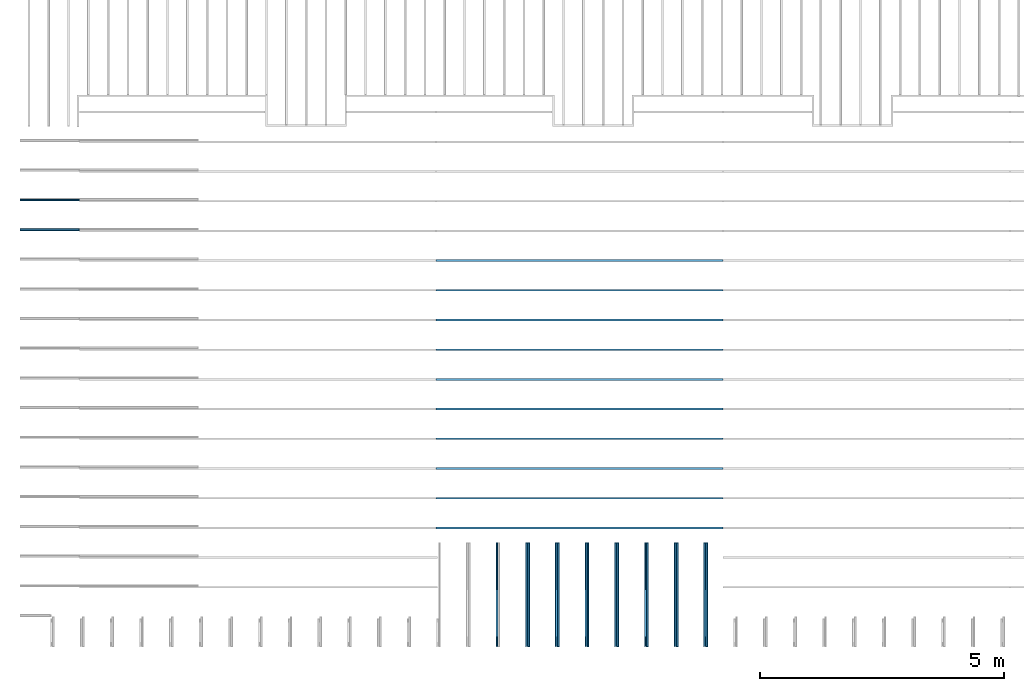
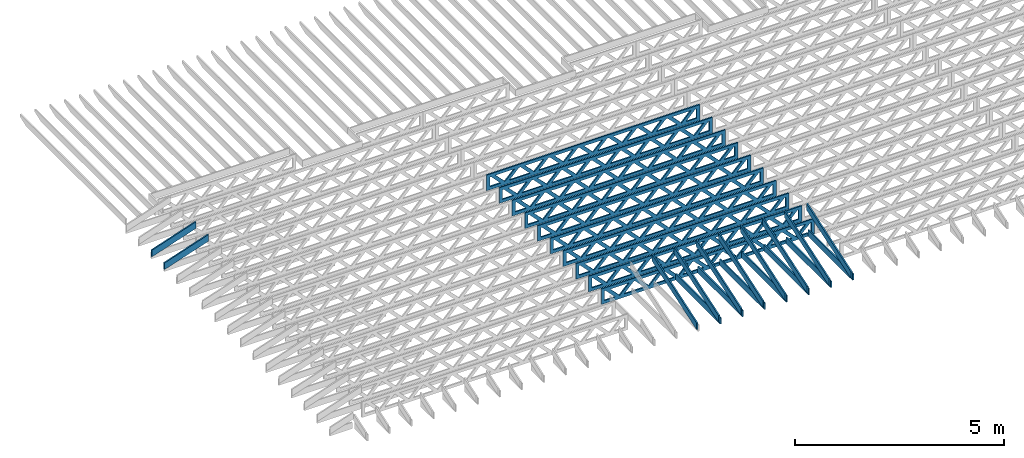
# One storey, part 3 of 18: 27 beams, 4 elements without a shape of their own.
"""IFC4 building model written with IfcOpenShell, lengths in feet."""

from ifc_helpers import new_model, entity, si_unit, converted_unit, derived_unit, direction, frame, frame_2d, origin, origin_2d_with_axis, place, context, subcontext, project, spatial, rectangle, extrude, clip, halfspace, source, transform, mapped, material, material_profile, profile_set, profile_usage, type_object, type_shapes, element, aggregate, save


model = new_model("IFC4")

# Units and contexts
model_context_1 = context("Model", 3, precision=0.0001, world=origin(), true_north=direction((6.12303176911189e-17, 1.0)))
model_context_2 = context("Model", 3, precision=0.0001, world=origin(), true_north=direction((6.12303176911189e-17, 1.0)))
body_context = subcontext(model_context_2, "Body", "Model", "MODEL_VIEW")
ifc_project = project(units=[converted_unit("LENGTHUNIT", "FOOT", entity("IfcRatioMeasure", 0.3048), si_unit("LENGTHUNIT", "METRE"), dimensions=[1, 0, 0, 0, 0, 0, 0]), converted_unit("AREAUNIT", "SQUARE FOOT", entity("IfcRatioMeasure", 0.09290304), si_unit("AREAUNIT", "SQUARE_METRE"), dimensions=[2, 0, 0, 0, 0, 0, 0]), converted_unit("VOLUMEUNIT", "CUBIC FOOT", entity("IfcRatioMeasure", 0.028316846592), si_unit("VOLUMEUNIT", "CUBIC_METRE"), dimensions=[3, 0, 0, 0, 0, 0, 0]), converted_unit("PLANEANGLEUNIT", "DEGREE", entity("IfcRatioMeasure", 0.0174532925199433), si_unit("PLANEANGLEUNIT", "RADIAN"), dimensions=[0, 0, 0, 0, 0, 0, 0]), si_unit("MASSUNIT", "GRAM", prefix="KILO"), derived_unit("MASSDENSITYUNIT", [(si_unit("MASSUNIT", "GRAM", prefix="KILO"), 1), (si_unit("LENGTHUNIT", "METRE"), -3)]), derived_unit("MOMENTOFINERTIAUNIT", [(si_unit("LENGTHUNIT", "METRE"), 4)]), si_unit("TIMEUNIT", "SECOND"), si_unit("FREQUENCYUNIT", "HERTZ"), si_unit("THERMODYNAMICTEMPERATUREUNIT", "DEGREE_CELSIUS"), derived_unit("THERMALTRANSMITTANCEUNIT", [(si_unit("MASSUNIT", "GRAM", prefix="KILO"), 1), (si_unit("THERMODYNAMICTEMPERATUREUNIT", "KELVIN"), -1), (si_unit("TIMEUNIT", "SECOND"), -3)]), derived_unit("VOLUMETRICFLOWRATEUNIT", [(si_unit("LENGTHUNIT", "METRE"), 3), (si_unit("TIMEUNIT", "SECOND"), -1)]), si_unit("ELECTRICCURRENTUNIT", "AMPERE"), si_unit("ELECTRICVOLTAGEUNIT", "VOLT"), si_unit("POWERUNIT", "WATT"), si_unit("FORCEUNIT", "NEWTON"), si_unit("ILLUMINANCEUNIT", "LUX"), si_unit("LUMINOUSFLUXUNIT", "LUMEN"), si_unit("LUMINOUSINTENSITYUNIT", "CANDELA"), derived_unit("USERDEFINED", [(si_unit("MASSUNIT", "GRAM", prefix="KILO"), -1), (si_unit("LENGTHUNIT", "METRE"), -2), (si_unit("TIMEUNIT", "SECOND"), 3), (si_unit("LUMINOUSFLUXUNIT", "LUMEN"), 1)]), derived_unit("LINEARVELOCITYUNIT", [(si_unit("LENGTHUNIT", "METRE"), 1), (si_unit("TIMEUNIT", "SECOND"), -1)]), si_unit("PRESSUREUNIT", "PASCAL"), derived_unit("USERDEFINED", [(si_unit("LENGTHUNIT", "METRE"), -2), (si_unit("MASSUNIT", "GRAM", prefix="KILO"), 1), (si_unit("TIMEUNIT", "SECOND"), -2)]), derived_unit("LINEARFORCEUNIT", [(si_unit("MASSUNIT", "GRAM", prefix="KILO"), 1), (si_unit("LENGTHUNIT", "METRE"), 1), (si_unit("TIMEUNIT", "SECOND"), -2), (si_unit("LENGTHUNIT", "METRE"), -1)]), derived_unit("PLANARFORCEUNIT", [(si_unit("MASSUNIT", "GRAM", prefix="KILO"), 1), (si_unit("LENGTHUNIT", "METRE"), 1), (si_unit("TIMEUNIT", "SECOND"), -2), (si_unit("LENGTHUNIT", "METRE"), -2)])], contexts=[model_context_1])

# Site, building, storey
site_placement = place(None, origin())
site = spatial("IfcSite", under=ifc_project, at=site_placement, CompositionType="ELEMENT")
building_placement = place(site_placement, origin())
building = spatial("IfcBuilding", under=site, at=building_placement, CompositionType="ELEMENT")
storey_placement = place(building_placement, frame((0.0, 0.0, 30.4375000000082)))
storey = spatial("IfcBuildingStorey", under=building, at=storey_placement, Name="ROOF", CompositionType="ELEMENT", Elevation=30.4375000000082)

# Assembly, beams
assembly_1_placement = place(storey_placement, origin())
assembly_1 = element("IfcElementAssembly", 1, at=assembly_1_placement, inside=storey, Name="Structural Beam System:Structural Framing System", ObjectType="Structural Beam System:Structural Framing System", AssemblyPlace="NOTDEFINED", PredefinedType="BEAM_GRID")
ifc_material_1 = material(Name="TOP CHORD OF FIELD FRAMED OVERHANG", Category="Materials")
ifc_material_profile_1 = material_profile(ifc_material_1, rectangle(XDim=0.604166666666667, YDim=0.125, at=origin_2d_with_axis()), Name="2X8 TOP CHORD")
ifc_profile_set_1 = profile_set([ifc_material_profile_1], Name="2X8 TOP CHORD")
ifc_profile_usage_1 = profile_usage(ifc_profile_set_1, cardinal=8)
beam_type_1 = type_object("IfcBeamType", Name="Dimension Lumber - Ends:2X8 TOP CHORD", PredefinedType="BEAM", material=ifc_profile_set_1)
shared_shape_1 = source(origin(), body_context, "Body", "Clipping", [
    clip(clip(extrude(rectangle(XDim=0.604166666666671, YDim=0.125, at=frame_2d((-1.83186799063151e-15, 0.0), x_axis=(1.0, 0.0))), frame((-2.10819527564865, 0.0, 0.0), z_axis=(1.0, 0.0, 0.0), x_axis=(0.0, 0.0, -1.0)), (0.0, 0.0, 1.0), 4.41772145980974), halfspace(frame((2.10819527564862, -0.0625000000000025, -0.302083333333339), z_axis=(0.948710608132914, 0.0, -0.316145823973807), x_axis=(0.0, 1.0, 0.0)), False)), halfspace(frame((-1.90686436713617, -0.0625000000000025, 0.302083333333328), z_axis=(-0.948710608132914, 0.0, 0.316145823973807), x_axis=(0.0, 1.0, 0.0)), False)),
])
type_shapes(beam_type_1, [shared_shape_1])
beam_1_placement = place(assembly_1_placement, frame((-267.833654839365, 949.945265019167, 1.93690371042362), z_axis=(-0.316227766016838, 0.0, 0.948683298050514), x_axis=(0.948683298050514, 0.0, 0.316227766016837)))
beam_1 = element("IfcBeam", 2, at=beam_1_placement, type_object=beam_type_1, material=ifc_profile_usage_1, Name="Dimension Lumber - Ends:2X8 TOP CHORD", ObjectType="Dimension Lumber - Ends:2X8 TOP CHORD", PredefinedType="BEAM", context=body_context, shape_type="MappedRepresentation", body=[
    mapped(shared_shape_1, transform((0.0, 0.0, 0.0), scale=1.0)),
])
ifc_profile_usage_2 = profile_usage(ifc_profile_set_1, cardinal=8)
beam_2_placement = place(assembly_1_placement, frame((-267.833654839365, 951.945265019167, 1.93690371042362), z_axis=(-0.316227766016838, 0.0, 0.948683298050514), x_axis=(0.948683298050514, 0.0, 0.316227766016837)))
beam_2 = element("IfcBeam", 3, at=beam_2_placement, type_object=beam_type_1, material=ifc_profile_usage_2, Name="Dimension Lumber - Ends:2X8 TOP CHORD", ObjectType="Dimension Lumber - Ends:2X8 TOP CHORD", PredefinedType="BEAM", context=body_context, shape_type="MappedRepresentation", body=[
    mapped(shared_shape_1, transform((0.0, 0.0, 0.0), scale=1.0)),
])
aggregate(assembly_1, [beam_1, beam_2])

assembly_2_placement = place(storey_placement, origin())
assembly_2 = element("IfcElementAssembly", 4, at=assembly_2_placement, inside=storey, Name="Structural Beam System:Structural Framing System", ObjectType="Structural Beam System:Structural Framing System", AssemblyPlace="NOTDEFINED", PredefinedType="BEAM_GRID")
ifc_profile_usage_3 = profile_usage(ifc_profile_set_1, cardinal=8)
beam_type_2 = type_object("IfcBeamType", Name="Dimension Lumber - Ends:2X8 TOP CHORD", PredefinedType="BEAM", material=ifc_profile_set_1)
shared_shape_2 = source(origin(), body_context, "Body", "Clipping", [
    clip(clip(extrude(rectangle(XDim=0.604166666666667, YDim=0.125, at=origin_2d_with_axis()), frame((-3.68932423085928, 0.0, 0.0), z_axis=(1.0, 0.0, 0.0), x_axis=(0.0, 0.0, -1.0)), (0.0, 0.0, 1.0), 7.57997937023103), halfspace(frame((3.68932423085925, -0.0625000000000025, -0.302083333333339), z_axis=(0.948710608132914, 0.0, -0.316145823973806), x_axis=(0.0, 1.0, 0.0)), False)), halfspace(frame((-3.4879933223468, -0.0625000000000025, 0.302083333333328), z_axis=(-0.948710608132914, 0.0, 0.316145823973805), x_axis=(0.0, 1.0, 0.0)), False)),
])
type_shapes(beam_type_2, [shared_shape_2])
beam_3_placement = place(assembly_2_placement, frame((-235.613158541548, 925.266392269532, 2.43688759934747), z_axis=(0.0, -0.316227766016848, 0.948683298050511), x_axis=(0.0, 0.948683298050511, 0.316227766016848)))
beam_3 = element("IfcBeam", 5, at=beam_3_placement, type_object=beam_type_2, material=ifc_profile_usage_3, Name="Dimension Lumber - Ends:2X8 TOP CHORD", ObjectType="Dimension Lumber - Ends:2X8 TOP CHORD", PredefinedType="BEAM", context=body_context, shape_type="MappedRepresentation", body=[
    mapped(shared_shape_2, transform((0.0, 0.0, 0.0), scale=1.0)),
])
ifc_profile_usage_4 = profile_usage(ifc_profile_set_1, cardinal=8)
beam_4_placement = place(assembly_2_placement, frame((-231.613158541547, 925.266392269532, 2.43688759934747), z_axis=(0.0, -0.316227766016852, 0.948683298050509), x_axis=(0.0, 0.948683298050509, 0.316227766016852)))
beam_4 = element("IfcBeam", 6, at=beam_4_placement, type_object=beam_type_2, material=ifc_profile_usage_4, Name="Dimension Lumber - Ends:2X8 TOP CHORD", ObjectType="Dimension Lumber - Ends:2X8 TOP CHORD", PredefinedType="BEAM", context=body_context, shape_type="MappedRepresentation", body=[
    mapped(shared_shape_2, transform((0.0, 0.0, 0.0), scale=1.0)),
])
ifc_profile_usage_5 = profile_usage(ifc_profile_set_1, cardinal=8)
beam_5_placement = place(assembly_2_placement, frame((-227.613158541547, 925.266392269532, 2.43688759934741), z_axis=(0.0, -0.316227766016852, 0.948683298050509), x_axis=(0.0, 0.948683298050509, 0.316227766016852)))
beam_5 = element("IfcBeam", 7, at=beam_5_placement, type_object=beam_type_2, material=ifc_profile_usage_5, Name="Dimension Lumber - Ends:2X8 TOP CHORD", ObjectType="Dimension Lumber - Ends:2X8 TOP CHORD", PredefinedType="BEAM", context=body_context, shape_type="MappedRepresentation", body=[
    mapped(shared_shape_2, transform((0.0, 0.0, 0.0), scale=1.0)),
])
ifc_profile_usage_6 = profile_usage(ifc_profile_set_1, cardinal=8)
beam_6_placement = place(assembly_2_placement, frame((-225.613158541547, 925.266392269532, 2.43688759934747), z_axis=(0.0, -0.316227766016851, 0.94868329805051), x_axis=(0.0, 0.94868329805051, 0.316227766016851)))
beam_6 = element("IfcBeam", 8, at=beam_6_placement, type_object=beam_type_2, material=ifc_profile_usage_6, Name="Dimension Lumber - Ends:2X8 TOP CHORD", ObjectType="Dimension Lumber - Ends:2X8 TOP CHORD", PredefinedType="BEAM", context=body_context, shape_type="MappedRepresentation", body=[
    mapped(shared_shape_2, transform((0.0, 0.0, 0.0), scale=1.0)),
])
ifc_profile_usage_7 = profile_usage(ifc_profile_set_1, cardinal=8)
beam_7_placement = place(assembly_2_placement, frame((-223.613158541547, 925.266392269532, 2.43688759934747), z_axis=(0.0, -0.316227766016851, 0.94868329805051), x_axis=(0.0, 0.94868329805051, 0.316227766016851)))
beam_7 = element("IfcBeam", 9, at=beam_7_placement, type_object=beam_type_2, material=ifc_profile_usage_7, Name="Dimension Lumber - Ends:2X8 TOP CHORD", ObjectType="Dimension Lumber - Ends:2X8 TOP CHORD", PredefinedType="BEAM", context=body_context, shape_type="MappedRepresentation", body=[
    mapped(shared_shape_2, transform((0.0, 0.0, 0.0), scale=1.0)),
])
ifc_profile_usage_8 = profile_usage(ifc_profile_set_1, cardinal=8)
beam_8_placement = place(assembly_2_placement, frame((-229.613158541547, 925.266392269532, 2.43688759934759), z_axis=(0.0, -0.316227766016851, 0.948683298050509), x_axis=(0.0, 0.948683298050509, 0.316227766016851)))
beam_8 = element("IfcBeam", 10, at=beam_8_placement, type_object=beam_type_2, material=ifc_profile_usage_8, Name="Dimension Lumber - Ends:2X8 TOP CHORD", ObjectType="Dimension Lumber - Ends:2X8 TOP CHORD", PredefinedType="BEAM", context=body_context, shape_type="MappedRepresentation", body=[
    mapped(shared_shape_2, transform((0.0, 0.0, 0.0), scale=1.0)),
])
ifc_profile_usage_9 = profile_usage(ifc_profile_set_1, cardinal=8)
beam_9_placement = place(assembly_2_placement, frame((-233.613158541548, 925.266392269532, 2.43688759934747), z_axis=(0.0, -0.316227766016848, 0.948683298050511), x_axis=(0.0, 0.948683298050511, 0.316227766016848)))
beam_9 = element("IfcBeam", 11, at=beam_9_placement, type_object=beam_type_2, material=ifc_profile_usage_9, Name="Dimension Lumber - Ends:2X8 TOP CHORD", ObjectType="Dimension Lumber - Ends:2X8 TOP CHORD", PredefinedType="BEAM", context=body_context, shape_type="MappedRepresentation", body=[
    mapped(shared_shape_2, transform((0.0, 0.0, 0.0), scale=1.0)),
])
ifc_profile_usage_10 = profile_usage(ifc_profile_set_1, cardinal=8)
beam_10_placement = place(assembly_2_placement, frame((-237.613158541548, 925.266392269532, 2.43688759934747), z_axis=(0.0, -0.316227766016848, 0.94868329805051), x_axis=(0.0, 0.94868329805051, 0.316227766016848)))
beam_10 = element("IfcBeam", 12, at=beam_10_placement, type_object=beam_type_2, material=ifc_profile_usage_10, Name="Dimension Lumber - Ends:2X8 TOP CHORD", ObjectType="Dimension Lumber - Ends:2X8 TOP CHORD", PredefinedType="BEAM", context=body_context, shape_type="MappedRepresentation", body=[
    mapped(shared_shape_2, transform((0.0, 0.0, 0.0), scale=1.0)),
])
aggregate(assembly_2, [beam_3, beam_4, beam_5, beam_6, beam_7, beam_8, beam_9, beam_10])

assembly_3_placement = place(storey_placement, origin())
assembly_3 = element("IfcElementAssembly", 13, at=assembly_3_placement, inside=storey, Name="Structural Beam System:Structural Framing System", ObjectType="Structural Beam System:Structural Framing System", AssemblyPlace="NOTDEFINED", PredefinedType="BEAM_GRID")
ifc_material_2 = material(Name="BOTTOM CHORD OF FIELD FRAMED OVERHANG", Category="Materials")
ifc_material_profile_2 = material_profile(ifc_material_2, rectangle(XDim=0.604166666666667, YDim=0.125000000000011, at=origin_2d_with_axis()), Name="2X8 - BOTTOM CHORD")
ifc_profile_set_2 = profile_set([ifc_material_profile_2], Name="2X8 - BOTTOM CHORD")
ifc_profile_usage_11 = profile_usage(ifc_profile_set_2, cardinal=8)
beam_type_3 = type_object("IfcBeamType", Name="061100 - Wood Framing:2X8 - BOTTOM CHORD", PredefinedType="BEAM", material=ifc_profile_set_2)
shared_shape_3 = source(origin(), body_context, "Body", "SweptSolid", [
    extrude(rectangle(XDim=0.604166666666667, YDim=0.125000000000011, at=origin_2d_with_axis()), frame((-3.49999999999926, 0.0, 0.0), z_axis=(1.0, 0.0, 0.0), x_axis=(0.0, 0.0, -1.0)), (0.0, 0.0, 1.0), 6.99999999999852),
])
type_shapes(beam_type_3, [shared_shape_3])
beam_11_placement = place(assembly_3_placement, frame((-229.488158437574, 925.361928245297, 1.07291666665406), z_axis=(0.0, 0.0, 1.0), x_axis=(0.0, -1.0, 0.0)))
beam_11 = element("IfcBeam", 14, at=beam_11_placement, type_object=beam_type_3, material=ifc_profile_usage_11, Name="061100 - Wood Framing:2X8 - BOTTOM CHORD", ObjectType="061100 - Wood Framing:2X8 - BOTTOM CHORD", PredefinedType="BEAM", context=body_context, shape_type="MappedRepresentation", body=[
    mapped(shared_shape_3, transform((0.0, 0.0, 0.0), scale=1.0)),
])
ifc_profile_usage_12 = profile_usage(ifc_profile_set_2, cardinal=8)
beam_12_placement = place(assembly_3_placement, frame((-227.488158437574, 925.361928747801, 1.07291666665406), z_axis=(0.0, 0.0, 1.0), x_axis=(0.0, -1.0, 0.0)))
beam_12 = element("IfcBeam", 15, at=beam_12_placement, type_object=beam_type_3, material=ifc_profile_usage_12, Name="061100 - Wood Framing:2X8 - BOTTOM CHORD", ObjectType="061100 - Wood Framing:2X8 - BOTTOM CHORD", PredefinedType="BEAM", context=body_context, shape_type="MappedRepresentation", body=[
    mapped(shared_shape_3, transform((0.0, 0.0, 0.0), scale=1.0)),
])
ifc_profile_usage_13 = profile_usage(ifc_profile_set_2, cardinal=8)
beam_13_placement = place(assembly_3_placement, frame((-223.488158437574, 925.361929752809, 1.07291666665406), z_axis=(0.0, 0.0, 1.0), x_axis=(0.0, -1.0, 0.0)))
beam_13 = element("IfcBeam", 16, at=beam_13_placement, type_object=beam_type_3, material=ifc_profile_usage_13, Name="061100 - Wood Framing:2X8 - BOTTOM CHORD", ObjectType="061100 - Wood Framing:2X8 - BOTTOM CHORD", PredefinedType="BEAM", context=body_context, shape_type="MappedRepresentation", body=[
    mapped(shared_shape_3, transform((0.0, 0.0, 0.0), scale=1.0)),
])
ifc_profile_usage_14 = profile_usage(ifc_profile_set_2, cardinal=8)
beam_14_placement = place(assembly_3_placement, frame((-225.488158437574, 925.361929250305, 1.07291666665406), z_axis=(0.0, 0.0, 1.0), x_axis=(0.0, -1.0, 0.0)))
beam_14 = element("IfcBeam", 17, at=beam_14_placement, type_object=beam_type_3, material=ifc_profile_usage_14, Name="061100 - Wood Framing:2X8 - BOTTOM CHORD", ObjectType="061100 - Wood Framing:2X8 - BOTTOM CHORD", PredefinedType="BEAM", context=body_context, shape_type="MappedRepresentation", body=[
    mapped(shared_shape_3, transform((0.0, 0.0, 0.0), scale=1.0)),
])
ifc_profile_usage_15 = profile_usage(ifc_profile_set_2, cardinal=8)
beam_15_placement = place(assembly_3_placement, frame((-231.488158437574, 925.361927742794, 1.07291666665406), z_axis=(0.0, 0.0, 1.0), x_axis=(0.0, -1.0, 0.0)))
beam_15 = element("IfcBeam", 18, at=beam_15_placement, type_object=beam_type_3, material=ifc_profile_usage_15, Name="061100 - Wood Framing:2X8 - BOTTOM CHORD", ObjectType="061100 - Wood Framing:2X8 - BOTTOM CHORD", PredefinedType="BEAM", context=body_context, shape_type="MappedRepresentation", body=[
    mapped(shared_shape_3, transform((0.0, 0.0, 0.0), scale=1.0)),
])
ifc_profile_usage_16 = profile_usage(ifc_profile_set_2, cardinal=8)
beam_16_placement = place(assembly_3_placement, frame((-233.488158437574, 925.36192724029, 1.07291666665406), z_axis=(0.0, 0.0, 1.0), x_axis=(0.0, -1.0, 0.0)))
beam_16 = element("IfcBeam", 19, at=beam_16_placement, type_object=beam_type_3, material=ifc_profile_usage_16, Name="061100 - Wood Framing:2X8 - BOTTOM CHORD", ObjectType="061100 - Wood Framing:2X8 - BOTTOM CHORD", PredefinedType="BEAM", context=body_context, shape_type="MappedRepresentation", body=[
    mapped(shared_shape_3, transform((0.0, 0.0, 0.0), scale=1.0)),
])
ifc_profile_usage_17 = profile_usage(ifc_profile_set_2, cardinal=8)
beam_17_placement = place(assembly_3_placement, frame((-235.488158437574, 925.361926737786, 1.07291666665406), z_axis=(0.0, 0.0, 1.0), x_axis=(0.0, -1.0, 0.0)))
beam_17 = element("IfcBeam", 20, at=beam_17_placement, type_object=beam_type_3, material=ifc_profile_usage_17, Name="061100 - Wood Framing:2X8 - BOTTOM CHORD", ObjectType="061100 - Wood Framing:2X8 - BOTTOM CHORD", PredefinedType="BEAM", context=body_context, shape_type="MappedRepresentation", body=[
    mapped(shared_shape_3, transform((0.0, 0.0, 0.0), scale=1.0)),
])
aggregate(assembly_3, [beam_11, beam_12, beam_13, beam_14, beam_15, beam_16, beam_17])

assembly_4_placement = place(storey_placement, origin())
assembly_4 = element("IfcElementAssembly", 21, at=assembly_4_placement, inside=storey, Name="Structural Beam System:Structural Framing System", ObjectType="Structural Beam System:Structural Framing System", AssemblyPlace="NOTDEFINED", PredefinedType="BEAM_GRID")
ifc_material_3 = material(Name="WOOD TRUSS", Category="Materials")
ifc_material_profile_3 = material_profile(ifc_material_3, rectangle(XDim=1.73473973950632, YDim=0.125, at=origin_2d_with_axis()))
ifc_material_profile_4 = material_profile(ifc_material_3, rectangle(XDim=1.73473973950633, YDim=0.125, at=frame_2d((-1.11022302462516e-16, 0.0), x_axis=(1.0, 0.0))))
ifc_material_profile_5 = material_profile(ifc_material_3, rectangle(XDim=1.73473973950632, YDim=0.125, at=origin_2d_with_axis()))
ifc_material_profile_6 = material_profile(ifc_material_3, rectangle(XDim=1.73473973950633, YDim=0.125, at=origin_2d_with_axis()))
ifc_material_profile_7 = material_profile(ifc_material_3, rectangle(XDim=1.73473973950632, YDim=0.125, at=frame_2d((-5.55111512312578e-17, 0.0), x_axis=(1.0, 0.0))))
ifc_material_profile_8 = material_profile(ifc_material_3, rectangle(XDim=1.73473973950633, YDim=0.125, at=frame_2d((-2.77555756156289e-16, 0.0), x_axis=(1.0, 0.0))))
ifc_material_profile_9 = material_profile(ifc_material_3, rectangle(XDim=1.73473973950632, YDim=0.125, at=frame_2d((-4.9960036108132e-16, 0.0), x_axis=(1.0, 0.0))))
ifc_material_profile_10 = material_profile(ifc_material_3, rectangle(XDim=1.73473973950633, YDim=0.125, at=frame_2d((4.44089209850063e-16, 0.0), x_axis=(1.0, 0.0))))
ifc_material_profile_11 = material_profile(ifc_material_3, rectangle(XDim=1.73473973950632, YDim=0.125, at=origin_2d_with_axis()))
ifc_material_profile_12 = material_profile(ifc_material_3, rectangle(XDim=1.73473973950633, YDim=0.125, at=frame_2d((-4.9960036108132e-16, 0.0), x_axis=(1.0, 0.0))))
ifc_material_profile_13 = material_profile(ifc_material_3, rectangle(XDim=0.291666666666664, YDim=0.125, at=frame_2d((-2.77555756156289e-17, 0.0), x_axis=(1.0, 0.0))))
ifc_material_profile_14 = material_profile(ifc_material_3, rectangle(XDim=0.291666666666628, YDim=0.124999999999995, at=frame_2d((-5.55111512312578e-17, 0.0), x_axis=(1.0, 0.0))))
ifc_material_profile_15 = material_profile(ifc_material_3, rectangle(XDim=0.916666666666666, YDim=0.125000000000003, at=frame_2d((-2.77555756156289e-17, 0.0), x_axis=(1.0, 0.0))))
ifc_material_profile_16 = material_profile(ifc_material_3, rectangle(XDim=0.916666666666651, YDim=0.125, at=frame_2d((-2.77555756156289e-17, 0.0), x_axis=(1.0, 0.0))))
ifc_profile_set_3 = profile_set([ifc_material_profile_3, ifc_material_profile_4, ifc_material_profile_5, ifc_material_profile_6, ifc_material_profile_7, ifc_material_profile_8, ifc_material_profile_9, ifc_material_profile_10, ifc_material_profile_11, ifc_material_profile_12, ifc_material_profile_13, ifc_material_profile_14, ifc_material_profile_15, ifc_material_profile_16])
ifc_profile_usage_18 = profile_usage(ifc_profile_set_3, cardinal=8)
beam_type_4 = type_object("IfcBeamType", PredefinedType="BEAM", material=ifc_profile_set_3)
shared_shape_4 = source(origin(), body_context, "Body", "SweptSolid", [
    extrude(rectangle(XDim=1.73473973950632, YDim=0.125, at=frame_2d((-5.55111512312578e-16, 0.0), x_axis=(1.0, 0.0))), frame((5.85339326404794, 0.0, 0.101118361020562), z_axis=(0.720569184836762, 0.0, -0.693383046997606), x_axis=(0.693383046997606, 0.0, 0.720569184836762)), (0.0, 0.0, 1.0), 0.291666666666667),
    extrude(rectangle(XDim=1.73473973950633, YDim=0.125, at=frame_2d((-4.9960036108132e-16, 0.0), x_axis=(1.0, 0.0))), frame((4.60310739037467, 0.0, -0.101118361020407), z_axis=(0.720569184836758, 0.0, 0.69338304699761), x_axis=(0.69338304699761, 0.0, -0.720569184836758)), (0.0, 0.0, 1.0), 0.291666666666667),
    extrude(rectangle(XDim=1.73473973950632, YDim=0.125, at=frame_2d((3.33066907387547e-16, 0.0), x_axis=(1.0, 0.0))), frame((3.18672659738144, 0.0, 0.101118361020562), z_axis=(0.720569184836762, 0.0, -0.693383046997606), x_axis=(0.693383046997606, 0.0, 0.720569184836762)), (0.0, 0.0, 1.0), 0.291666666666667),
    extrude(rectangle(XDim=1.73473973950633, YDim=0.125, at=frame_2d((-1.11022302462516e-16, 0.0), x_axis=(1.0, 0.0))), frame((1.93644072370817, 0.0, -0.101118361020407), z_axis=(0.720569184836758, 0.0, 0.69338304699761), x_axis=(0.69338304699761, 0.0, -0.720569184836758)), (0.0, 0.0, 1.0), 0.291666666666666),
    extrude(rectangle(XDim=1.73473973950632, YDim=0.125, at=frame_2d((5.55111512312578e-17, 0.0), x_axis=(1.0, 0.0))), frame((0.520059930714937, 0.0, 0.101118361020562), z_axis=(0.720569184836762, 0.0, -0.693383046997606), x_axis=(0.693383046997606, 0.0, 0.720569184836762)), (0.0, 0.0, 1.0), 0.291666666666667),
    extrude(rectangle(XDim=1.73473973950633, YDim=0.125, at=origin_2d_with_axis()), frame((-0.730225942958334, 0.0, -0.101118361020407), z_axis=(0.720569184836758, 0.0, 0.69338304699761), x_axis=(0.69338304699761, 0.0, -0.720569184836758)), (0.0, 0.0, 1.0), 0.291666666666666),
    extrude(rectangle(XDim=1.73473973950632, YDim=0.125, at=frame_2d((-5.55111512312578e-17, 0.0), x_axis=(1.0, 0.0))), frame((-2.14660673595157, 0.0, 0.101118361020562), z_axis=(0.720569184836762, 0.0, -0.693383046997606), x_axis=(0.693383046997606, 0.0, 0.720569184836762)), (0.0, 0.0, 1.0), 0.291666666666667),
    extrude(rectangle(XDim=1.73473973950633, YDim=0.125, at=frame_2d((-2.77555756156289e-16, 0.0), x_axis=(1.0, 0.0))), frame((-3.39689260962484, 0.0, -0.101118361020407), z_axis=(0.720569184836758, 0.0, 0.69338304699761), x_axis=(0.69338304699761, 0.0, -0.720569184836758)), (0.0, 0.0, 1.0), 0.291666666666666),
    extrude(rectangle(XDim=1.73473973950632, YDim=0.125, at=origin_2d_with_axis()), frame((-4.81327340261807, 0.0, 0.101118361020562), z_axis=(0.720569184836762, 0.0, -0.693383046997606), x_axis=(0.693383046997606, 0.0, 0.720569184836762)), (0.0, 0.0, 1.0), 0.291666666666667),
    extrude(rectangle(XDim=1.73473973950633, YDim=0.125, at=frame_2d((-4.9960036108132e-16, 0.0), x_axis=(1.0, 0.0))), frame((-6.06355927629134, 0.0, -0.101118361020407), z_axis=(0.720569184836758, 0.0, 0.69338304699761), x_axis=(0.69338304699761, 0.0, -0.720569184836758)), (0.0, 0.0, 1.0), 0.291666666666667),
    extrude(rectangle(XDim=1.73473973950632, YDim=0.125, at=frame_2d((-1.0547118733939e-15, 0.0), x_axis=(1.0, 0.0))), frame((8.52005993071445, 0.0, 0.101118361020506), z_axis=(0.720569184836761, 0.0, -0.693383046997607), x_axis=(0.693383046997607, 0.0, 0.720569184836761)), (0.0, 0.0, 1.0), 0.291666666666667),
    extrude(rectangle(XDim=1.73473973950633, YDim=0.125, at=origin_2d_with_axis()), frame((7.26977405704118, 0.0, -0.101118361020463), z_axis=(0.720569184836758, 0.0, 0.69338304699761), x_axis=(0.69338304699761, 0.0, -0.720569184836758)), (0.0, 0.0, 1.0), 0.291666666666667),
    extrude(rectangle(XDim=1.73473973950632, YDim=0.125, at=frame_2d((4.44089209850063e-16, 0.0), x_axis=(1.0, 0.0))), frame((-7.47994006928457, 0.0, 0.101118361020561), z_axis=(0.720569184836762, 0.0, -0.693383046997606), x_axis=(0.693383046997606, 0.0, 0.720569184836762)), (0.0, 0.0, 1.0), 0.291666666666666),
    extrude(rectangle(XDim=1.73473973950633, YDim=0.125, at=origin_2d_with_axis()), frame((-8.73022594295784, 0.0, -0.101118361020408), z_axis=(0.720569184836758, 0.0, 0.69338304699761), x_axis=(0.69338304699761, 0.0, -0.720569184836758)), (0.0, 0.0, 1.0), 0.291666666666666),
    extrude(rectangle(XDim=0.291666666666664, YDim=0.125, at=frame_2d((-2.77555756156289e-17, 0.0), x_axis=(1.0, 0.0))), frame((-9.66666666666609, 0.0, 0.604166666666611), z_axis=(1.0, 0.0, 0.0), x_axis=(0.0, 0.0, -1.0)), (0.0, 0.0, 1.0), 19.3333333333322),
    extrude(rectangle(XDim=0.291666666666628, YDim=0.124999999999995, at=frame_2d((-5.55111512312578e-17, 0.0), x_axis=(1.0, 0.0))), frame((-9.66666666666588, 0.0, -0.604166666666693), z_axis=(1.0, 0.0, 0.0), x_axis=(0.0, 0.0, -1.0)), (0.0, 0.0, 1.0), 19.333333333332),
    extrude(rectangle(XDim=0.916666666666666, YDim=0.125000000000003, at=frame_2d((-2.77555756156289e-17, 0.0), x_axis=(1.0, 0.0))), frame((9.3749999999994, 0.0, 0.0), z_axis=(1.0, 0.0, 0.0), x_axis=(0.0, 0.0, -1.0)), (0.0, 0.0, 1.0), 0.291666666666687),
    extrude(rectangle(XDim=0.916666666666651, YDim=0.125, at=frame_2d((-2.77555756156289e-17, 0.0), x_axis=(1.0, 0.0))), frame((-9.66666666666609, 0.0, 0.0), z_axis=(1.0, 0.0, 0.0), x_axis=(0.0, 0.0, -1.0)), (0.0, 0.0, 1.0), 0.291666666666687),
])
type_shapes(beam_type_4, [shared_shape_4])
beam_18_placement = place(assembly_4_placement, frame((-232.071493818828, 929.861934882651, 0.74999999999168)))
beam_18 = element("IfcBeam", 22, at=beam_18_placement, type_object=beam_type_4, material=ifc_profile_usage_18, PredefinedType="BEAM", context=body_context, shape_type="MappedRepresentation", body=[
    mapped(shared_shape_4, transform((0.0, 0.0, 0.0), scale=1.0)),
])
ifc_profile_usage_19 = profile_usage(ifc_profile_set_3, cardinal=8)
beam_19_placement = place(assembly_4_placement, frame((-232.071493818828, 931.861934882651, 0.74999999999168)))
beam_19 = element("IfcBeam", 23, at=beam_19_placement, type_object=beam_type_4, material=ifc_profile_usage_19, PredefinedType="BEAM", context=body_context, shape_type="MappedRepresentation", body=[
    mapped(shared_shape_4, transform((0.0, 0.0, 0.0), scale=1.0)),
])
ifc_profile_usage_20 = profile_usage(ifc_profile_set_3, cardinal=8)
beam_20_placement = place(assembly_4_placement, frame((-232.071493818828, 933.861934882651, 0.749999999991672)))
beam_20 = element("IfcBeam", 24, at=beam_20_placement, type_object=beam_type_4, material=ifc_profile_usage_20, PredefinedType="BEAM", context=body_context, shape_type="MappedRepresentation", body=[
    mapped(shared_shape_4, transform((0.0, 0.0, 0.0), scale=1.0)),
])
ifc_profile_usage_21 = profile_usage(ifc_profile_set_3, cardinal=8)
beam_21_placement = place(assembly_4_placement, frame((-232.071493818828, 935.861934882651, 0.749999999991665)))
beam_21 = element("IfcBeam", 25, at=beam_21_placement, type_object=beam_type_4, material=ifc_profile_usage_21, PredefinedType="BEAM", context=body_context, shape_type="MappedRepresentation", body=[
    mapped(shared_shape_4, transform((0.0, 0.0, 0.0), scale=1.0)),
])
ifc_profile_usage_22 = profile_usage(ifc_profile_set_3, cardinal=8)
beam_22_placement = place(assembly_4_placement, frame((-232.071493818828, 937.861934882651, 0.749999999991658)))
beam_22 = element("IfcBeam", 26, at=beam_22_placement, type_object=beam_type_4, material=ifc_profile_usage_22, PredefinedType="BEAM", context=body_context, shape_type="MappedRepresentation", body=[
    mapped(shared_shape_4, transform((0.0, 0.0, 0.0), scale=1.0)),
])
ifc_profile_usage_23 = profile_usage(ifc_profile_set_3, cardinal=8)
beam_23_placement = place(assembly_4_placement, frame((-232.071493818828, 939.861934882651, 0.749999999991651)))
beam_23 = element("IfcBeam", 27, at=beam_23_placement, type_object=beam_type_4, material=ifc_profile_usage_23, PredefinedType="BEAM", context=body_context, shape_type="MappedRepresentation", body=[
    mapped(shared_shape_4, transform((0.0, 0.0, 0.0), scale=1.0)),
])
ifc_profile_usage_24 = profile_usage(ifc_profile_set_3, cardinal=8)
beam_24_placement = place(assembly_4_placement, frame((-232.071493818828, 941.861934882651, 0.749999999991651)))
beam_24 = element("IfcBeam", 28, at=beam_24_placement, type_object=beam_type_4, material=ifc_profile_usage_24, PredefinedType="BEAM", context=body_context, shape_type="MappedRepresentation", body=[
    mapped(shared_shape_4, transform((0.0, 0.0, 0.0), scale=1.0)),
])
ifc_profile_usage_25 = profile_usage(ifc_profile_set_3, cardinal=8)
beam_25_placement = place(assembly_4_placement, frame((-232.071493818828, 943.861934882651, 0.749999999991644)))
beam_25 = element("IfcBeam", 29, at=beam_25_placement, type_object=beam_type_4, material=ifc_profile_usage_25, PredefinedType="BEAM", context=body_context, shape_type="MappedRepresentation", body=[
    mapped(shared_shape_4, transform((0.0, 0.0, 0.0), scale=1.0)),
])
ifc_profile_usage_26 = profile_usage(ifc_profile_set_3, cardinal=8)
beam_26_placement = place(assembly_4_placement, frame((-232.071493818828, 945.861934882651, 0.749999999991637)))
beam_26 = element("IfcBeam", 30, at=beam_26_placement, type_object=beam_type_4, material=ifc_profile_usage_26, PredefinedType="BEAM", context=body_context, shape_type="MappedRepresentation", body=[
    mapped(shared_shape_4, transform((0.0, 0.0, 0.0), scale=1.0)),
])
ifc_profile_usage_27 = profile_usage(ifc_profile_set_3, cardinal=8)
beam_27_placement = place(assembly_4_placement, frame((-232.071493818828, 947.861934882651, 0.74999999999163)))
beam_27 = element("IfcBeam", 31, at=beam_27_placement, type_object=beam_type_4, material=ifc_profile_usage_27, PredefinedType="BEAM", context=body_context, shape_type="MappedRepresentation", body=[
    mapped(shared_shape_4, transform((0.0, 0.0, 0.0), scale=1.0)),
])
aggregate(assembly_4, [beam_18, beam_19, beam_20, beam_21, beam_22, beam_23, beam_24, beam_25, beam_26, beam_27])

save(model, "model.ifc")
